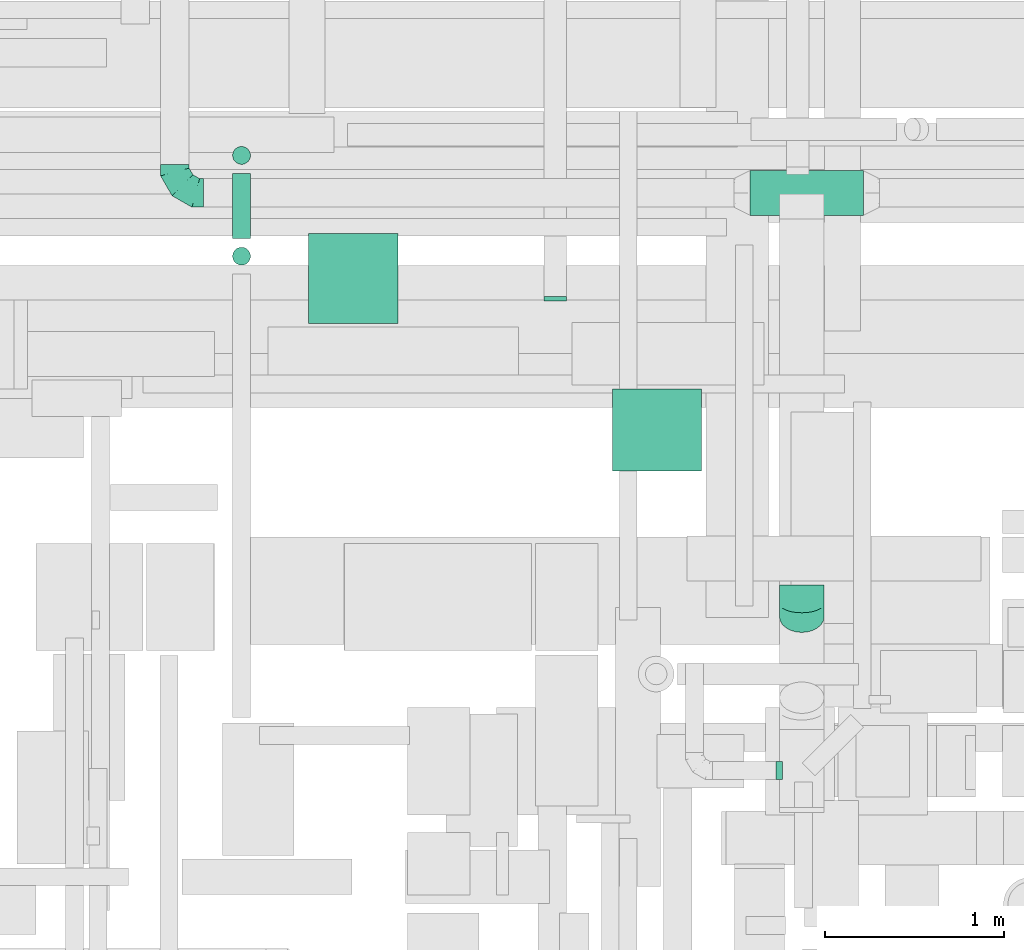
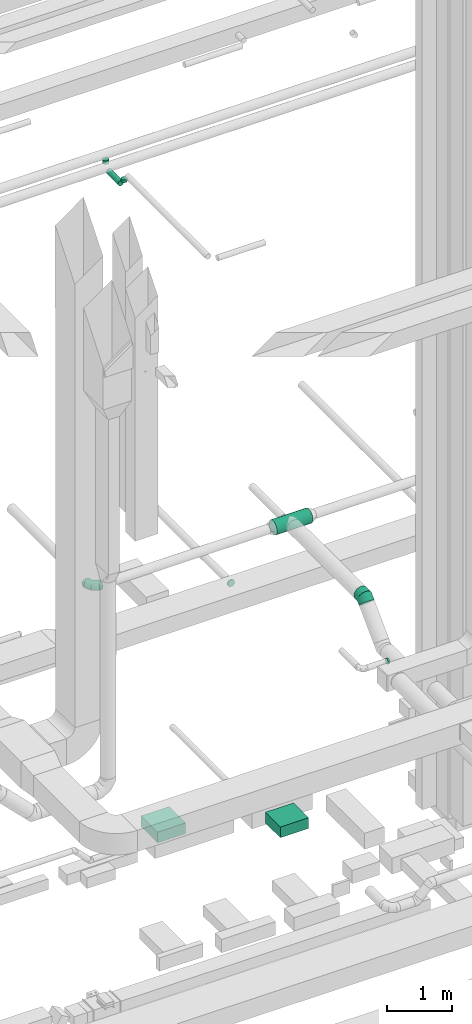
# One storey, part 138 of 337: 6 flow segments, 4 flow fittings.
"""IFC2X3 building model written with IfcOpenShell, lengths in millimetres."""

import ifcopenshell
import ifcopenshell.guid

model = None  # the IFC model being written
_history = None  # IfcOwnerHistory: only IFC2X3 demands one
_inside = {}  # id of a spatial element -> (the spatial element, [elements in it])
_under = {}  # id of a project, library or spatial element -> (it, [spatial elements below it])
_declared = {}  # id of a project -> (the project, [libraries it declares])
_typed = {}  # id of a type object -> (the type object, [elements of that type])
_made_of = {}  # id of a material, layer set ... -> (it, [elements and type objects made of it])


def new_model(schema):
    """Start an empty IFC model of exactly this schema.

    Asked for "IFC4X3", IfcOpenShell would pick the latest addendum, in which some entities
    have other attributes; the version numbers below select the first issue.
    IFC2X3 requires an IfcOwnerHistory on every rooted entity: one is made here for all.
    """
    global model, _history
    if schema == "IFC4X3":
        model = ifcopenshell.file(schema_version=(4, 3, 0, 0))
    else:
        model = ifcopenshell.file(schema=schema)
    _inside.clear()
    _under.clear()
    _declared.clear()
    _typed.clear()
    _made_of.clear()
    _history = None
    if model.schema == "IFC2X3":
        org = make("IfcOrganization", Name="unknown")
        user = make(
            "IfcPersonAndOrganization",
            ThePerson=make("IfcPerson", FamilyName="unknown"),
            TheOrganization=org,
        )
        app = make(
            "IfcApplication",
            ApplicationDeveloper=org,
            Version="unknown",
            ApplicationFullName="unknown",
            ApplicationIdentifier="unknown",
        )
        _history = make(
            "IfcOwnerHistory",
            OwningUser=user,
            OwningApplication=app,
            ChangeAction="ADDED",
            CreationDate=0,
        )
    return model


def make(cls, **values):
    """One entity of the class cls with the attributes given. An attribute that is None is left unset."""
    return model.create_entity(
        cls, **{name: value for name, value in values.items() if value is not None}
    )


def entity(cls, *values):
    """Any entity or typed value of the class cls, its attributes in the order of the schema. None: left unset."""
    e = model.create_entity(cls)
    for i, value in enumerate(values):
        if value is not None:
            e[i] = value
    return e


def rooted(cls, **values):
    """An entity with a GlobalId (a new one), such as an element, a storey or a relation."""
    return make(cls, GlobalId=ifcopenshell.guid.new(), OwnerHistory=_history, **values)


def si_unit(unit_type, name, prefix=None):
    """IfcSIUnit, for example si_unit("LENGTHUNIT", "METRE", prefix="MILLI")."""
    return make("IfcSIUnit", UnitType=unit_type, Prefix=prefix, Name=name)


def converted_unit(unit_type, name, factor, base, dimensions=None, offset=None):
    """IfcConversionBasedUnit, such as the inch: factor (a typed value) times the base unit."""
    return make(
        "IfcConversionBasedUnit"
        if offset is None
        else "IfcConversionBasedUnitWithOffset",
        ConversionOffset=offset,
        Dimensions=None
        if dimensions is None
        else entity("IfcDimensionalExponents", *dimensions),
        UnitType=unit_type,
        Name=name,
        ConversionFactor=make(
            "IfcMeasureWithUnit", ValueComponent=factor, UnitComponent=base
        ),
    )


def derived_unit(unit_type, elements):
    """IfcDerivedUnit: a product of units, each with its exponent."""
    return make(
        "IfcDerivedUnit",
        Elements=[
            make("IfcDerivedUnitElement", Unit=unit, Exponent=power)
            for unit, power in elements
        ],
        UnitType=unit_type,
    )


def assignment(units):
    """IfcUnitAssignment: the units of a project."""
    return None if units is None else make("IfcUnitAssignment", Units=units)


def point(xyz):
    """IfcCartesianPoint."""
    return None if xyz is None else make("IfcCartesianPoint", Coordinates=xyz)


def direction(xyz):
    """IfcDirection."""
    return None if xyz is None else make("IfcDirection", DirectionRatios=xyz)


def frame(location, z_axis=None, x_axis=None):
    """IfcAxis2Placement3D, a coordinate frame: its origin and axes. An axis left out is left unset."""
    return make(
        "IfcAxis2Placement3D",
        Location=point(location),
        Axis=direction(z_axis),
        RefDirection=direction(x_axis),
    )


def frame_2d(location, x_axis=None):
    """IfcAxis2Placement2D, a coordinate frame in the plane: its origin and x axis."""
    return make(
        "IfcAxis2Placement2D", Location=point(location), RefDirection=direction(x_axis)
    )


def origin():
    """The frame at (0, 0, 0) with its axes left unset."""
    return frame((0.0, 0.0, 0.0))


def origin_2d_with_axis():
    """The frame at (0, 0) in the plane with the x axis (1, 0) written out."""
    return frame_2d((0.0, 0.0), x_axis=(1.0, 0.0))


def place(relative_to, where):
    """IfcLocalPlacement: puts the frame where relative to a parent placement (None: the world)."""
    return make(
        "IfcLocalPlacement", PlacementRelTo=relative_to, RelativePlacement=where
    )


def context(
    kind, dimensions, precision=None, world=None, true_north=None, identifier=None
):
    """IfcGeometricRepresentationContext, for example the 3D "Model" context."""
    return make(
        "IfcGeometricRepresentationContext",
        ContextIdentifier=identifier,
        ContextType=kind,
        CoordinateSpaceDimension=dimensions,
        Precision=precision,
        WorldCoordinateSystem=world,
        TrueNorth=true_north,
    )


def subcontext(parent, identifier, kind, view, scale=None):
    """IfcGeometricRepresentationSubContext, for example "Body" below "Model"."""
    return make(
        "IfcGeometricRepresentationSubContext",
        ContextIdentifier=identifier,
        ContextType=kind,
        ParentContext=parent,
        TargetScale=scale,
        TargetView=view,
    )


def project(units=None, contexts=None):
    """IfcProject with its units and contexts."""
    return rooted(
        "IfcProject",
        Name="project",
        RepresentationContexts=contexts,
        UnitsInContext=assignment(units),
    )


def spatial(cls, under=None, at=None, **own):
    """A site, building, storey or space (cls), placed at a placement, below another one or the project."""
    s = rooted(cls, ObjectPlacement=at, **own)
    if under is not None:
        _under.setdefault(under.id(), (under, []))[1].append(s)
    return s


def profile(cls, at=None, kind="AREA", **sizes):
    """A parametric profile (cls). Its sizes go by their IFC names, for example OverallWidth=200.0."""
    return make(cls, ProfileType=kind, Position=at, **sizes)


def rectangle(**sizes):
    """IfcRectangleProfileDef."""
    return profile("IfcRectangleProfileDef", **sizes)


def circle(**sizes):
    """IfcCircleProfileDef."""
    return profile("IfcCircleProfileDef", **sizes)


def extrude(swept, where, along, depth):
    """IfcExtrudedAreaSolid: the profile swept, set in the frame where, extruded along a direction by depth."""
    return make(
        "IfcExtrudedAreaSolid",
        SweptArea=swept,
        Position=where,
        ExtrudedDirection=direction(along),
        Depth=depth,
    )


def faces_of(points, faces, orient=None, outer=None):
    """IfcFace entities. A face is a list of loops; a loop is a list of indices into points, from 0.

    orient and outer hold one flag for each loop. By default every Orientation is true, the
    first loop of a face is its IfcFaceOuterBound and the others are IfcFaceBound.
    """
    made = []
    for i, loops in enumerate(faces):
        bounds = []
        for j, loop in enumerate(loops):
            is_outer = j == 0 if outer is None else outer[i][j]
            bounds.append(
                make(
                    "IfcFaceOuterBound" if is_outer else "IfcFaceBound",
                    Bound=make("IfcPolyLoop", Polygon=[points[k] for k in loop]),
                    Orientation=True if orient is None else orient[i][j],
                )
            )
        made.append(make("IfcFace", Bounds=bounds))
    return made


def faceted_brep(points, faces, orient=None, outer=None, voids=None):
    """IfcFacetedBrep: a solid bounded by flat faces; with voids (closed shells), ...WithVoids."""
    shared = [point(p) for p in points]
    hull = make("IfcClosedShell", CfsFaces=faces_of(shared, faces, orient, outer))
    if voids is None:
        return make("IfcFacetedBrep", Outer=hull)
    return make(
        "IfcFacetedBrepWithVoids",
        Outer=hull,
        Voids=[
            make(cls, CfsFaces=faces_of(shared, fs, o, b)) for cls, fs, o, b in voids
        ],
    )


def shape(context_of_items, identifier, shape_type, items):
    """IfcShapeRepresentation: the items that make up one representation, for example the "Body"."""
    return make(
        "IfcShapeRepresentation",
        ContextOfItems=context_of_items,
        RepresentationIdentifier=identifier,
        RepresentationType=shape_type,
        Items=items,
    )


def source(mapping_origin, context_of_items, identifier, shape_type, items):
    """IfcRepresentationMap: a shape defined once, which mapped items show again and again."""
    return make(
        "IfcRepresentationMap",
        MappingOrigin=mapping_origin,
        MappedRepresentation=shape(context_of_items, identifier, shape_type, items),
    )


def transform(
    local_origin,
    x_axis=None,
    y_axis=None,
    z_axis=None,
    scale=None,
    scale2=None,
    scale3=None,
    uniform=True,
):
    """IfcCartesianTransformationOperator3D, or its non-uniform kind. x_axis, y_axis, z_axis: its Axis1, 2, 3."""
    if uniform:
        return make(
            "IfcCartesianTransformationOperator3D",
            Axis1=direction(x_axis),
            Axis2=direction(y_axis),
            LocalOrigin=point(local_origin),
            Scale=scale,
            Axis3=direction(z_axis),
        )
    return make(
        "IfcCartesianTransformationOperator3DnonUniform",
        Axis1=direction(x_axis),
        Axis2=direction(y_axis),
        LocalOrigin=point(local_origin),
        Scale=scale,
        Axis3=direction(z_axis),
        Scale2=scale2,
        Scale3=scale3,
    )


def mapped(mapping_source, mapping_target):
    """IfcMappedItem: shows the shape of a source again, moved by a transform."""
    return make(
        "IfcMappedItem", MappingSource=mapping_source, MappingTarget=mapping_target
    )


def material(Name=None, Category=None):
    """IfcMaterial."""
    return make("IfcMaterial", Name=Name, Category=Category)


def made_of(thing, what):
    """Note that an element or type object is made of a material, layer set ...; save() writes the relation."""
    if what is not None:
        _made_of.setdefault(what.id(), (what, []))[1].append(thing)
    return thing


def type_object(cls, material=None, **own):
    """A type object (cls), such as IfcWallType, which elements share."""
    return made_of(rooted(cls, **own), material)


def type_shapes(of_type, sources):
    """Give a type object the sources (RepresentationMaps) that its elements show as mapped items."""
    of_type.RepresentationMaps = sources


def element(
    cls,
    number,
    at=None,
    inside=None,
    cuts=None,
    type_object=None,
    material=None,
    context=None,
    identifier="Body",
    shape_type=None,
    held_by="IfcProductDefinitionShape",
    body=None,
    shapes=None,
    **own,
):
    """One element of the class cls, such as IfcWall. Its Tag is "e" and its number.

    at: its placement. inside: the storey or other place that contains it. cuts: it is an
    opening in that element (IfcRelVoidsElement). A single representation is given by context,
    identifier, shape_type and body (its items); several are given by shapes. held_by: the class
    of the entity that holds the representations. save() writes the other relations.
    """
    e = rooted(cls, Tag="e%d" % number, ObjectPlacement=at, **own)
    if body is not None:
        shapes = [shape(context, identifier, shape_type, body)]
    if shapes is not None:
        e.Representation = make(held_by, Representations=shapes)
    if inside is not None:
        _inside.setdefault(inside.id(), (inside, []))[1].append(e)
    if cuts is not None:
        rooted(
            "IfcRelVoidsElement", RelatingBuildingElement=cuts, RelatedOpeningElement=e
        )
    if type_object is not None:
        _typed.setdefault(type_object.id(), (type_object, []))[1].append(e)
    return made_of(e, material)


def aggregate(whole, parts):
    """IfcRelAggregates: a whole, such as a stair, and the parts it consists of."""
    return rooted("IfcRelAggregates", RelatingObject=whole, RelatedObjects=parts)


def save(model, path):
    """Write the relations noted so far, then the file.

    IfcRelAggregates (storeys below a building ...), IfcRelContainedInSpatialStructure (elements
    in a storey), IfcRelDefinesByType, IfcRelAssociatesMaterial and IfcRelDeclares: one each for
    every whole, place, type object, material and project.
    """
    for whole, parts in _under.values():
        aggregate(whole, parts)
    for where, things in _inside.values():
        rooted(
            "IfcRelContainedInSpatialStructure",
            RelatedElements=things,
            RelatingStructure=where,
        )
    for kind, things in _typed.values():
        rooted("IfcRelDefinesByType", RelatedObjects=things, RelatingType=kind)
    for what, things in _made_of.values():
        rooted("IfcRelAssociatesMaterial", RelatedObjects=things, RelatingMaterial=what)
    for by, libraries in _declared.values():
        rooted("IfcRelDeclares", RelatingContext=by, RelatedDefinitions=libraries)
    model.write(path)


model = new_model("IFC2X3")

# Units and contexts
model_context = context("Model", 3, precision=0.01, world=origin(), true_north=direction((6.12303176911189e-17, 1.0)))
body_context = subcontext(model_context, "Body", "Model", "MODEL_VIEW")
ifc_project = project(units=[si_unit("LENGTHUNIT", "METRE", prefix="MILLI"), si_unit("AREAUNIT", "SQUARE_METRE"), si_unit("VOLUMEUNIT", "CUBIC_METRE"), converted_unit("PLANEANGLEUNIT", "DEGREE", entity("IfcRatioMeasure", 0.0174532925199433), si_unit("PLANEANGLEUNIT", "RADIAN"), dimensions=[0, 0, 0, 0, 0, 0, 0]), si_unit("MASSUNIT", "GRAM", prefix="KILO"), derived_unit("MASSDENSITYUNIT", [(si_unit("MASSUNIT", "GRAM", prefix="KILO"), 1), (si_unit("LENGTHUNIT", "METRE"), -3)]), derived_unit("MOMENTOFINERTIAUNIT", [(si_unit("LENGTHUNIT", "METRE"), 4)]), si_unit("TIMEUNIT", "SECOND"), si_unit("FREQUENCYUNIT", "HERTZ"), si_unit("THERMODYNAMICTEMPERATUREUNIT", "DEGREE_CELSIUS"), derived_unit("THERMALTRANSMITTANCEUNIT", [(si_unit("MASSUNIT", "GRAM", prefix="KILO"), 1), (si_unit("THERMODYNAMICTEMPERATUREUNIT", "KELVIN"), -1), (si_unit("TIMEUNIT", "SECOND"), -3)]), derived_unit("VOLUMETRICFLOWRATEUNIT", [(si_unit("LENGTHUNIT", "METRE"), 3), (si_unit("TIMEUNIT", "SECOND"), -1)]), derived_unit("MASSFLOWRATEUNIT", [(si_unit("MASSUNIT", "GRAM", prefix="KILO"), 1), (si_unit("TIMEUNIT", "SECOND"), -1)]), derived_unit("ROTATIONALFREQUENCYUNIT", [(si_unit("TIMEUNIT", "SECOND"), -1)]), si_unit("ELECTRICCURRENTUNIT", "AMPERE"), si_unit("ELECTRICVOLTAGEUNIT", "VOLT"), si_unit("POWERUNIT", "WATT"), si_unit("FORCEUNIT", "NEWTON", prefix="KILO"), si_unit("ILLUMINANCEUNIT", "LUX"), si_unit("LUMINOUSFLUXUNIT", "LUMEN"), si_unit("LUMINOUSINTENSITYUNIT", "CANDELA"), derived_unit("USERDEFINED", [(si_unit("MASSUNIT", "GRAM", prefix="KILO"), -1), (si_unit("LENGTHUNIT", "METRE"), -2), (si_unit("TIMEUNIT", "SECOND"), 3), (si_unit("LUMINOUSFLUXUNIT", "LUMEN"), 1)]), derived_unit("LINEARVELOCITYUNIT", [(si_unit("LENGTHUNIT", "METRE"), 1), (si_unit("TIMEUNIT", "SECOND"), -1)]), si_unit("PRESSUREUNIT", "PASCAL"), derived_unit("USERDEFINED", [(si_unit("LENGTHUNIT", "METRE"), -2), (si_unit("MASSUNIT", "GRAM", prefix="KILO"), 1), (si_unit("TIMEUNIT", "SECOND"), -2)]), derived_unit("LINEARFORCEUNIT", [(si_unit("MASSUNIT", "GRAM", prefix="KILO"), 1), (si_unit("LENGTHUNIT", "METRE"), 1), (si_unit("TIMEUNIT", "SECOND"), -2), (si_unit("LENGTHUNIT", "METRE"), -1)]), derived_unit("PLANARFORCEUNIT", [(si_unit("MASSUNIT", "GRAM", prefix="KILO"), 1), (si_unit("LENGTHUNIT", "METRE"), 1), (si_unit("TIMEUNIT", "SECOND"), -2), (si_unit("LENGTHUNIT", "METRE"), -2)])], contexts=[model_context])

# Site, building, storey
site_placement = place(None, origin())
site = spatial("IfcSite", under=ifc_project, at=site_placement, CompositionType="ELEMENT")
building_placement = place(site_placement, origin())
building = spatial("IfcBuilding", under=site, at=building_placement, CompositionType="ELEMENT")
storey_placement = place(building_placement, origin())
storey = spatial("IfcBuildingStorey", under=building, at=storey_placement, CompositionType="ELEMENT", Elevation=0.0)

# Flow segments
duct_segment_type_1 = type_object("IfcDuctSegmentType", PredefinedType="NOTDEFINED")
flow_segment_1_placement = place(storey_placement, frame((27100.8, 14493.99, -1000.0)))
element("IfcFlowSegment", 1, at=flow_segment_1_placement, inside=storey, type_object=duct_segment_type_1, context=body_context, shape_type="SweptSolid", body=[
    extrude(rectangle(XDim=505.000017000369, YDim=499.999999999999, at=origin_2d_with_axis()), frame((250.0, 252.5, 0.0), z_axis=(0.0, 0.0, 1.0), x_axis=(0.0, 1.0, 0.0)), (0.0, 0.0, 1.0), 200.0),
])
flow_segment_2_placement = place(storey_placement, frame((28801.33, 13668.99, -1000.0)))
element("IfcFlowSegment", 2, at=flow_segment_2_placement, inside=storey, type_object=duct_segment_type_1, context=body_context, shape_type="SweptSolid", body=[
    extrude(rectangle(XDim=459.999999999878, YDim=499.999999999999, at=origin_2d_with_axis()), frame((250.0, 230.0, 0.0), z_axis=(0.0, 0.0, 1.0), x_axis=(0.0, -1.0, 0.0)), (0.0, 0.0, 1.0), 200.0),
])
duct_segment_type_2 = type_object("IfcDuctSegmentType", PredefinedType="NOTDEFINED")
flow_segment_3_placement = place(storey_placement, frame((26674.61, 14970.85, 11148.4)))
element("IfcFlowSegment", 3, at=flow_segment_3_placement, inside=storey, type_object=duct_segment_type_2, context=body_context, shape_type="SweptSolid", body=[
    extrude(circle(Radius=50.0, at=origin_2d_with_axis()), frame((51.6, 0.0, 51.6), z_axis=(0.0, 1.0, 0.0), x_axis=(1.0, 0.0, 0.0)), (0.0, 0.0, 1.0), 363.99999999998),
])
flow_segment_4_placement = place(storey_placement, frame((29571.25, 15098.34, 3473.4)))
element("IfcFlowSegment", 4, at=flow_segment_4_placement, inside=storey, type_object=duct_segment_type_2, context=body_context, shape_type="SweptSolid", body=[
    extrude(circle(Radius=125.0, at=origin_2d_with_axis()), frame((0.0, 126.6, 126.6), z_axis=(1.0, 0.0, 0.0), x_axis=(0.0, 1.0, 0.0)), (0.0, 0.0, 1.0), 635.000000000046),
])
flow_segment_5_placement = place(storey_placement, frame((26674.61, 15383.25, 11300.0)))
element("IfcFlowSegment", 5, at=flow_segment_5_placement, inside=storey, type_object=duct_segment_type_2, context=body_context, shape_type="SweptSolid", body=[
    extrude(circle(Radius=50.0, at=origin_2d_with_axis()), frame((51.6, 51.6, 0.0), z_axis=(0.0, 0.0, 1.0), x_axis=(-1.0, 0.0, 0.0)), (0.0, 0.0, 1.0), 69.9999999999841),
])
flow_segment_6_placement = place(storey_placement, frame((26674.61, 14819.25, 11300.0)))
element("IfcFlowSegment", 6, at=flow_segment_6_placement, inside=storey, type_object=duct_segment_type_2, context=body_context, shape_type="SweptSolid", body=[
    extrude(circle(Radius=50.0, at=origin_2d_with_axis()), frame((51.6, 51.6, 0.0), z_axis=(0.0, 0.0, 1.0), x_axis=(-1.0, 0.0, 0.0)), (0.0, 0.0, 1.0), 50.0000000000276),
])

# Flow fittings
ifc_material = material()
duct_fitting_type_1 = type_object("IfcDuctFittingType", PredefinedType="NOTDEFINED", material=ifc_material)
shared_shape_1 = source(origin(), body_context, "Body", "Brep", [
    faceted_brep([(-160.0, 0.0, -80.0), (-160.0, -20.71, -77.27), (-160.0, -40.0, -69.28), (-160.0, -56.57, -56.57), (-160.0, -69.28, -40.0), (-160.0, -77.27, -20.71), (-160.0, -80.0, 0.0), (-160.0, -77.27, 20.71), (-160.0, -69.28, 40.0), (-160.0, -56.57, 56.57), (-160.0, -40.0, 69.28), (-160.0, -20.71, 77.27), (-160.0, 0.0, 80.0), (-160.0, 20.71, 77.27), (-160.0, 40.0, 69.28), (-160.0, 56.57, 56.57), (-160.0, 69.28, 40.0), (-160.0, 77.27, 20.71), (-160.0, 80.0, 0.0), (-160.0, 77.27, -20.71), (-160.0, 69.28, -40.0), (-160.0, 56.57, -56.57), (-160.0, 40.0, -69.28), (-160.0, 20.71, -77.27), (-122.68, 20.71, 77.27), (-127.85, 40.0, 69.28), (-117.13, 0.0, 80.0), (-132.29, 56.57, 56.57), (-137.83, 77.27, 20.71), (-138.56, 80.0, 0.0), (-135.69, 69.28, 40.0), (-135.69, 69.28, -40.0), (-132.29, 56.57, -56.57), (-137.83, 77.27, -20.71), (-122.68, 20.71, -77.27), (-117.13, 0.0, -80.0), (-127.85, 40.0, -69.28), (-111.58, -20.71, -77.27), (-106.41, -40.0, -69.28), (-101.97, -56.57, -56.57), (-98.56, -69.28, -40.0), (-96.42, -77.27, -20.71), (-95.69, -80.0, 0.0), (-96.42, -77.27, 20.71), (-98.56, -69.28, 40.0), (-101.97, -56.57, 56.57), (-106.41, -40.0, 69.28), (-111.58, -20.71, 77.27), (-58.03, 58.03, 77.27), (-72.15, 72.15, 69.28), (-42.87, 42.87, 80.0), (-84.28, 84.28, 56.57), (-93.59, 93.59, 40.0), (-99.44, 99.44, 20.71), (-101.44, 101.44, 0.0), (-99.44, 99.44, -20.71), (-93.59, 93.59, -40.0), (-84.28, 84.28, -56.57), (-58.03, 58.03, -77.27), (-42.87, 42.87, -80.0), (-72.15, 72.15, -69.28), (-27.71, 27.71, -77.27), (-13.59, 13.59, -69.28), (-1.46, 1.46, -56.57), (7.85, -7.85, -40.0), (13.7, -13.7, -20.71), (15.69, -15.69, 0.0), (13.7, -13.7, 20.71), (7.85, -7.85, 40.0), (-1.46, 1.46, 56.57), (-13.59, 13.59, 69.28), (-27.71, 27.71, 77.27), (-20.71, 122.68, 77.27), (-40.0, 127.85, 69.28), (0.0, 117.13, 80.0), (-56.57, 132.29, 56.57), (-69.28, 135.69, 40.0), (-77.27, 137.83, 20.71), (-80.0, 138.56, 0.0), (-77.27, 137.83, -20.71), (-69.28, 135.69, -40.0), (-56.57, 132.29, -56.57), (-20.71, 122.68, -77.27), (0.0, 117.13, -80.0), (-40.0, 127.85, -69.28), (20.71, 111.58, -77.27), (40.0, 106.41, -69.28), (56.57, 101.97, -56.57), (69.28, 98.56, -40.0), (77.27, 96.42, -20.71), (80.0, 95.69, 0.0), (77.27, 96.42, 20.71), (69.28, 98.56, 40.0), (56.57, 101.97, 56.57), (40.0, 106.41, 69.28), (20.71, 111.58, 77.27), (-20.71, 160.0, -77.27), (-40.0, 160.0, -69.28), (-56.57, 160.0, -56.57), (-69.28, 160.0, -40.0), (-77.27, 160.0, -20.71), (-80.0, 160.0, 0.0), (-77.27, 160.0, 20.71), (-69.28, 160.0, 40.0), (-56.57, 160.0, 56.57), (-40.0, 160.0, 69.28), (-20.71, 160.0, 77.27), (0.0, 160.0, 80.0), (20.71, 160.0, 77.27), (40.0, 160.0, 69.28), (56.57, 160.0, 56.57), (69.28, 160.0, 40.0), (77.27, 160.0, 20.71), (80.0, 160.0, 0.0), (77.27, 160.0, -20.71), (69.28, 160.0, -40.0), (56.57, 160.0, -56.57), (40.0, 160.0, -69.28), (20.71, 160.0, -77.27), (0.0, 160.0, -80.0)], [[[0, 1, 2, 3, 4, 5, 6, 7, 8, 9, 10, 11, 12, 13, 14, 15, 16, 17, 18, 19, 20, 21, 22, 23]], [[24, 25, 14, 13]], [[26, 24, 13, 12]], [[14, 25, 27, 15]], [[28, 29, 18, 17]], [[30, 28, 17, 16]], [[15, 27, 30, 16]], [[20, 31, 32, 21]], [[33, 31, 20, 19]], [[18, 29, 33, 19]], [[34, 35, 0, 23]], [[36, 34, 23, 22]], [[32, 36, 22, 21]], [[1, 0, 35, 37]], [[2, 1, 37, 38]], [[3, 2, 38, 39]], [[5, 4, 40, 41]], [[6, 5, 41, 42]], [[39, 40, 4, 3]], [[6, 42, 43, 7]], [[7, 43, 44, 8]], [[8, 44, 45, 9]], [[9, 45, 46, 10]], [[10, 46, 47, 11]], [[26, 12, 11, 47]], [[48, 49, 25, 24]], [[50, 48, 24, 26]], [[27, 25, 49, 51]], [[52, 53, 28, 30]], [[51, 52, 30, 27]], [[29, 28, 53, 54]], [[55, 56, 31, 33]], [[54, 55, 33, 29]], [[32, 31, 56, 57]], [[58, 59, 35, 34]], [[60, 58, 34, 36]], [[57, 60, 36, 32]], [[37, 35, 59, 61]], [[38, 37, 61, 62]], [[39, 38, 62, 63]], [[41, 40, 64, 65]], [[42, 41, 65, 66]], [[63, 64, 40, 39]], [[43, 42, 66, 67]], [[44, 43, 67, 68]], [[68, 69, 45, 44]], [[46, 45, 69, 70]], [[47, 46, 70, 71]], [[26, 47, 71, 50]], [[72, 73, 49, 48]], [[74, 72, 48, 50]], [[51, 49, 73, 75]], [[76, 77, 53, 52]], [[75, 76, 52, 51]], [[54, 53, 77, 78]], [[79, 80, 56, 55]], [[78, 79, 55, 54]], [[57, 56, 80, 81]], [[82, 83, 59, 58]], [[84, 82, 58, 60]], [[81, 84, 60, 57]], [[61, 59, 83, 85]], [[62, 61, 85, 86]], [[63, 62, 86, 87]], [[65, 64, 88, 89]], [[66, 65, 89, 90]], [[87, 88, 64, 63]], [[67, 66, 90, 91]], [[68, 67, 91, 92]], [[92, 93, 69, 68]], [[70, 69, 93, 94]], [[71, 70, 94, 95]], [[50, 71, 95, 74]], [[96, 97, 98, 99, 100, 101, 102, 103, 104, 105, 106, 107, 108, 109, 110, 111, 112, 113, 114, 115, 116, 117, 118, 119]], [[72, 74, 107, 106]], [[73, 72, 106, 105]], [[75, 73, 105, 104]], [[77, 76, 103, 102]], [[78, 77, 102, 101]], [[75, 104, 103, 76]], [[78, 101, 100, 79]], [[79, 100, 99, 80]], [[80, 99, 98, 81]], [[84, 97, 96, 82]], [[82, 96, 119, 83]], [[84, 81, 98, 97]], [[118, 117, 86, 85]], [[119, 118, 85, 83]], [[116, 87, 86, 117]], [[88, 115, 114, 89]], [[89, 114, 113, 90]], [[115, 88, 87, 116]], [[112, 111, 92, 91]], [[113, 112, 91, 90]], [[111, 110, 93, 92]], [[95, 94, 109, 108]], [[74, 95, 108, 107]], [[110, 109, 94, 93]]]),
])
type_shapes(duct_fitting_type_1, [shared_shape_1])
flow_fitting_1_placement = place(storey_placement, frame((26353.13, 15224.94, 3600.0), z_axis=(0.0, 0.0, 1.0), x_axis=(0.0, -1.0, 0.0)))
element("IfcFlowFitting", 7, at=flow_fitting_1_placement, inside=storey, type_object=duct_fitting_type_1, material=ifc_material, context=body_context, shape_type="MappedRepresentation", body=[
    mapped(shared_shape_1, transform((0.0, 0.0, 0.0), scale=1.0)),
])
duct_fitting_type_2 = type_object("IfcDuctFittingType", PredefinedType="NOTDEFINED", material=ifc_material)
shared_shape_2 = source(origin(), body_context, "Body", "Brep", [
    faceted_brep([(20.0, 16.18, -60.37), (20.0, 31.25, -54.13), (20.0, 44.19, -44.19), (20.0, 54.13, -31.25), (20.0, 60.37, -16.18), (20.0, 62.5, 0.0), (20.0, 60.37, 16.18), (20.0, 54.13, 31.25), (20.0, 44.19, 44.19), (20.0, 31.25, 54.13), (20.0, 16.18, 60.37), (20.0, 0.0, 62.5), (20.0, -16.18, 60.37), (20.0, -31.25, 54.13), (20.0, -44.19, 44.19), (20.0, -54.13, 31.25), (20.0, -60.37, 16.18), (20.0, -62.5, 0.0), (20.0, -60.37, -16.18), (20.0, -54.13, -31.25), (20.0, -44.19, -44.19), (20.0, -31.25, -54.13), (20.0, -16.18, -60.37), (20.0, 0.0, -62.5), (0.0, 0.0, 62.5), (0.0, 16.18, 60.37), (-6.1, 16.18, 60.37), (-6.1, 0.0, 62.5), (0.0, 31.25, 54.13), (-6.1, 31.25, 54.13), (0.0, 44.19, 44.19), (-6.1, 44.19, 44.19), (0.0, 54.13, 31.25), (0.0, 60.37, 16.18), (-6.1, 60.37, 16.18), (-6.1, 54.13, 31.25), (0.0, 62.5, 0.0), (-6.1, 62.5, 0.0), (0.0, 60.37, -16.18), (-6.1, 60.37, -16.18), (0.0, 54.13, -31.25), (-6.1, 54.13, -31.25), (0.0, 44.19, -44.19), (-6.1, 44.19, -44.19), (0.0, 31.25, -54.13), (0.0, 16.18, -60.37), (-6.1, 16.18, -60.37), (-6.1, 31.25, -54.13), (0.0, 0.0, -62.5), (-6.1, 0.0, -62.5), (0.0, -16.18, -60.37), (-6.1, -16.18, -60.37), (0.0, -31.25, -54.13), (-6.1, -31.25, -54.13), (0.0, -44.19, -44.19), (-6.1, -44.19, -44.19), (0.0, -54.13, -31.25), (0.0, -60.37, -16.18), (-6.1, -60.37, -16.18), (-6.1, -54.13, -31.25), (0.0, -62.5, 0.0), (-6.1, -62.5, 0.0), (0.0, -60.37, 16.18), (-6.1, -60.37, 16.18), (0.0, -54.13, 31.25), (-6.1, -54.13, 31.25), (0.0, -44.19, 44.19), (-6.1, -44.19, 44.19), (0.0, -31.25, 54.13), (0.0, -16.18, 60.37), (-6.1, -16.18, 60.37), (-6.1, -31.25, 54.13)], [[[0, 1, 2, 3, 4, 5, 6, 7, 8, 9, 10, 11, 12, 13, 14, 15, 16, 17, 18, 19, 20, 21, 22, 23]], [[24, 11, 10, 25, 26, 27]], [[25, 10, 9, 28, 29, 26]], [[28, 9, 8, 30, 31, 29]], [[32, 7, 6, 33, 34, 35]], [[33, 6, 5, 36, 37, 34]], [[30, 8, 7, 32, 35, 31]], [[36, 5, 4, 38, 39, 37]], [[38, 4, 3, 40, 41, 39]], [[40, 3, 2, 42, 43, 41]], [[44, 1, 0, 45, 46, 47]], [[45, 0, 23, 48, 49, 46]], [[42, 2, 1, 44, 47, 43]], [[48, 23, 22, 50, 51, 49]], [[50, 22, 21, 52, 53, 51]], [[52, 21, 20, 54, 55, 53]], [[56, 19, 18, 57, 58, 59]], [[57, 18, 17, 60, 61, 58]], [[54, 20, 19, 56, 59, 55]], [[60, 17, 16, 62, 63, 61]], [[62, 16, 15, 64, 65, 63]], [[64, 15, 14, 66, 67, 65]], [[68, 13, 12, 69, 70, 71]], [[69, 12, 11, 24, 27, 70]], [[66, 14, 13, 68, 71, 67]], [[49, 51, 53, 55, 59, 58, 61, 63, 65, 67, 71, 70, 27, 26, 29, 31, 35, 34, 37, 39, 41, 43, 47, 46]]]),
])
type_shapes(duct_fitting_type_2, [shared_shape_2])
flow_fitting_2_placement = place(storey_placement, frame((28481.88, 14626.58, 3300.0), z_axis=(0.0, 0.0, -1.0), x_axis=(0.0, 1.0, 0.0)))
element("IfcFlowFitting", 8, at=flow_fitting_2_placement, inside=storey, type_object=duct_fitting_type_2, material=ifc_material, context=body_context, shape_type="MappedRepresentation", body=[
    mapped(shared_shape_2, transform((0.0, 0.0, 0.0), scale=1.0)),
])
duct_fitting_type_3 = type_object("IfcDuctFittingType", PredefinedType="NOTDEFINED", material=ifc_material)
shared_shape_3 = source(origin(), body_context, "Body", "Brep", [
    faceted_brep([(-103.55, 0.0, -125.0), (-103.55, -32.35, -120.74), (-103.55, -62.5, -108.25), (-103.55, -88.39, -88.39), (-103.55, -108.25, -62.5), (-103.55, -120.74, -32.35), (-103.55, -125.0, 0.0), (-103.55, -120.74, 32.35), (-103.55, -108.25, 62.5), (-103.55, -88.39, 88.39), (-103.55, -62.5, 108.25), (-103.55, -32.35, 120.74), (-103.55, 0.0, 125.0), (-103.55, 32.35, 120.74), (-103.55, 62.5, 108.25), (-103.55, 88.39, 88.39), (-103.55, 108.25, 62.5), (-103.55, 120.74, 32.35), (-103.55, 125.0, 0.0), (-103.55, 120.74, -32.35), (-103.55, 108.25, -62.5), (-103.55, 88.39, -88.39), (-103.55, 62.5, -108.25), (-103.55, 32.35, -120.74), (-13.4, 32.35, 120.74), (-25.89, 62.5, 108.25), (0.0, 0.0, 125.0), (-36.61, 88.39, 88.39), (-44.84, 108.25, 62.5), (-50.01, 120.74, 32.35), (-51.78, 125.0, 0.0), (-50.01, 120.74, -32.35), (-44.84, 108.25, -62.5), (-36.61, 88.39, -88.39), (-13.4, 32.35, -120.74), (0.0, 0.0, -125.0), (-25.89, 62.5, -108.25), (13.4, -32.35, -120.74), (25.89, -62.5, -108.25), (36.61, -88.39, -88.39), (44.84, -108.25, -62.5), (50.01, -120.74, -32.35), (51.78, -125.0, 0.0), (50.01, -120.74, 32.35), (44.84, -108.25, 62.5), (36.61, -88.39, 88.39), (25.89, -62.5, 108.25), (13.4, -32.35, 120.74), (73.22, 73.22, 125.0), (50.35, 96.1, 120.74), (29.03, 117.42, 108.25), (10.72, 135.72, 88.39), (-3.32, 149.77, 62.5), (-12.15, 158.6, 32.35), (-15.17, 161.61, 0.0), (-12.15, 158.6, -32.35), (-3.32, 149.77, -62.5), (10.72, 135.72, -88.39), (29.03, 117.42, -108.25), (50.35, 96.1, -120.74), (73.22, 73.22, -125.0), (96.1, 50.35, -120.74), (117.42, 29.03, -108.25), (135.72, 10.72, -88.39), (149.77, -3.32, -62.5), (158.6, -12.15, -32.35), (161.61, -15.17, 0.0), (158.6, -12.15, 32.35), (149.77, -3.32, 62.5), (135.72, 10.72, 88.39), (117.42, 29.03, 108.25), (96.1, 50.35, 120.74)], [[[0, 1, 2, 3, 4, 5, 6, 7, 8, 9, 10, 11, 12, 13, 14, 15, 16, 17, 18, 19, 20, 21, 22, 23]], [[24, 25, 14, 13]], [[26, 24, 13, 12]], [[14, 25, 27, 15]], [[28, 29, 17, 16]], [[28, 16, 15, 27]], [[30, 18, 17, 29]], [[31, 32, 20, 19]], [[30, 31, 19, 18]], [[32, 33, 21, 20]], [[34, 35, 0, 23]], [[36, 34, 23, 22]], [[33, 36, 22, 21]], [[1, 0, 35, 37]], [[2, 1, 37, 38]], [[38, 39, 3, 2]], [[5, 4, 40, 41]], [[6, 5, 41, 42]], [[39, 40, 4, 3]], [[6, 42, 43, 7]], [[7, 43, 44, 8]], [[8, 44, 45, 9]], [[9, 45, 46, 10]], [[10, 46, 47, 11]], [[26, 12, 11, 47]], [[24, 26, 48, 49]], [[25, 24, 49, 50]], [[27, 25, 50, 51]], [[29, 28, 52, 53]], [[30, 29, 53, 54]], [[51, 52, 28, 27]], [[30, 54, 55, 31]], [[31, 55, 56, 32]], [[57, 33, 32, 56]], [[36, 58, 59, 34]], [[34, 59, 60, 35]], [[58, 36, 33, 57]], [[35, 60, 61, 37]], [[37, 61, 62, 38]], [[63, 39, 38, 62]], [[40, 64, 65, 41]], [[41, 65, 66, 42]], [[64, 40, 39, 63]], [[43, 42, 66, 67]], [[44, 43, 67, 68]], [[68, 69, 45, 44]], [[47, 46, 70, 71]], [[26, 47, 71, 48]], [[69, 70, 46, 45]], [[59, 58, 57, 56, 55, 54, 53, 52, 51, 50, 49, 48, 71, 70, 69, 68, 67, 66, 65, 64, 63, 62, 61, 60]]]),
])
type_shapes(duct_fitting_type_3, [shared_shape_3])
flow_fitting_3_placement = place(storey_placement, frame((29861.25, 12927.19, 3600.0), z_axis=(-1.0, 0.0, 0.0), x_axis=(0.0, 0.707106781186461, 0.707106781186634)))
element("IfcFlowFitting", 9, at=flow_fitting_3_placement, inside=storey, type_object=duct_fitting_type_3, material=ifc_material, context=body_context, shape_type="MappedRepresentation", body=[
    mapped(shared_shape_3, transform((0.0, 0.0, 0.0), scale=1.0)),
])
duct_fitting_type_4 = type_object("IfcDuctFittingType", PredefinedType="NOTDEFINED", material=ifc_material)
shared_shape_4 = source(origin(), body_context, "Body", "Brep", [
    faceted_brep([(20.0, 12.94, -48.3), (20.0, 25.0, -43.3), (20.0, 35.36, -35.36), (20.0, 43.3, -25.0), (20.0, 48.3, -12.94), (20.0, 50.0, 0.0), (20.0, 48.3, 12.94), (20.0, 43.3, 25.0), (20.0, 35.36, 35.36), (20.0, 25.0, 43.3), (20.0, 12.94, 48.3), (20.0, 0.0, 50.0), (20.0, -12.94, 48.3), (20.0, -25.0, 43.3), (20.0, -35.36, 35.36), (20.0, -43.3, 25.0), (20.0, -48.3, 12.94), (20.0, -50.0, 0.0), (20.0, -48.3, -12.94), (20.0, -43.3, -25.0), (20.0, -35.36, -35.36), (20.0, -25.0, -43.3), (20.0, -12.94, -48.3), (20.0, 0.0, -50.0), (0.0, 0.0, 50.0), (0.0, 12.94, 48.3), (-16.53, 12.94, 48.3), (-16.53, 0.0, 50.0), (0.0, 25.0, 43.3), (-16.53, 25.0, 43.3), (0.0, 35.36, 35.36), (-16.53, 35.36, 35.36), (0.0, 43.3, 25.0), (0.0, 48.3, 12.94), (-16.53, 48.3, 12.94), (-16.53, 43.3, 25.0), (0.0, 50.0, 0.0), (-16.53, 50.0, 0.0), (0.0, 48.3, -12.94), (-16.53, 48.3, -12.94), (0.0, 43.3, -25.0), (-16.53, 43.3, -25.0), (0.0, 35.36, -35.36), (-16.53, 35.36, -35.36), (0.0, 25.0, -43.3), (0.0, 12.94, -48.3), (-16.53, 12.94, -48.3), (-16.53, 25.0, -43.3), (0.0, 0.0, -50.0), (-16.53, 0.0, -50.0), (0.0, -12.94, -48.3), (-16.53, -12.94, -48.3), (0.0, -25.0, -43.3), (-16.53, -25.0, -43.3), (0.0, -35.36, -35.36), (-16.53, -35.36, -35.36), (0.0, -43.3, -25.0), (0.0, -48.3, -12.94), (-16.53, -48.3, -12.94), (-16.53, -43.3, -25.0), (0.0, -50.0, 0.0), (-16.53, -50.0, 0.0), (0.0, -48.3, 12.94), (-16.53, -48.3, 12.94), (0.0, -43.3, 25.0), (-16.53, -43.3, 25.0), (0.0, -35.36, 35.36), (-16.53, -35.36, 35.36), (0.0, -25.0, 43.3), (0.0, -12.94, 48.3), (-16.53, -12.94, 48.3), (-16.53, -25.0, 43.3)], [[[0, 1, 2, 3, 4, 5, 6, 7, 8, 9, 10, 11, 12, 13, 14, 15, 16, 17, 18, 19, 20, 21, 22, 23]], [[24, 11, 10, 25, 26, 27]], [[25, 10, 9, 28, 29, 26]], [[28, 9, 8, 30, 31, 29]], [[32, 7, 6, 33, 34, 35]], [[33, 6, 5, 36, 37, 34]], [[30, 8, 7, 32, 35, 31]], [[36, 5, 4, 38, 39, 37]], [[38, 4, 3, 40, 41, 39]], [[40, 3, 2, 42, 43, 41]], [[44, 1, 0, 45, 46, 47]], [[45, 0, 23, 48, 49, 46]], [[42, 2, 1, 44, 47, 43]], [[48, 23, 22, 50, 51, 49]], [[50, 22, 21, 52, 53, 51]], [[52, 21, 20, 54, 55, 53]], [[56, 19, 18, 57, 58, 59]], [[57, 18, 17, 60, 61, 58]], [[54, 20, 19, 56, 59, 55]], [[60, 17, 16, 62, 63, 61]], [[62, 16, 15, 64, 65, 63]], [[64, 15, 14, 66, 67, 65]], [[68, 13, 12, 69, 70, 71]], [[69, 12, 11, 24, 27, 70]], [[66, 14, 13, 68, 71, 67]], [[49, 51, 53, 55, 59, 58, 61, 63, 65, 67, 71, 70, 27, 26, 29, 31, 35, 34, 37, 39, 41, 43, 47, 46]]]),
])
type_shapes(duct_fitting_type_4, [shared_shape_4])
flow_fitting_4_placement = place(storey_placement, frame((29736.25, 11993.44, 3000.0), z_axis=(0.0, 0.0, -1.0), x_axis=(-1.0, 0.0, 0.0)))
element("IfcFlowFitting", 10, at=flow_fitting_4_placement, inside=storey, type_object=duct_fitting_type_4, material=ifc_material, context=body_context, shape_type="MappedRepresentation", body=[
    mapped(shared_shape_4, transform((0.0, 0.0, 0.0), scale=1.0)),
])

save(model, "model.ifc")
